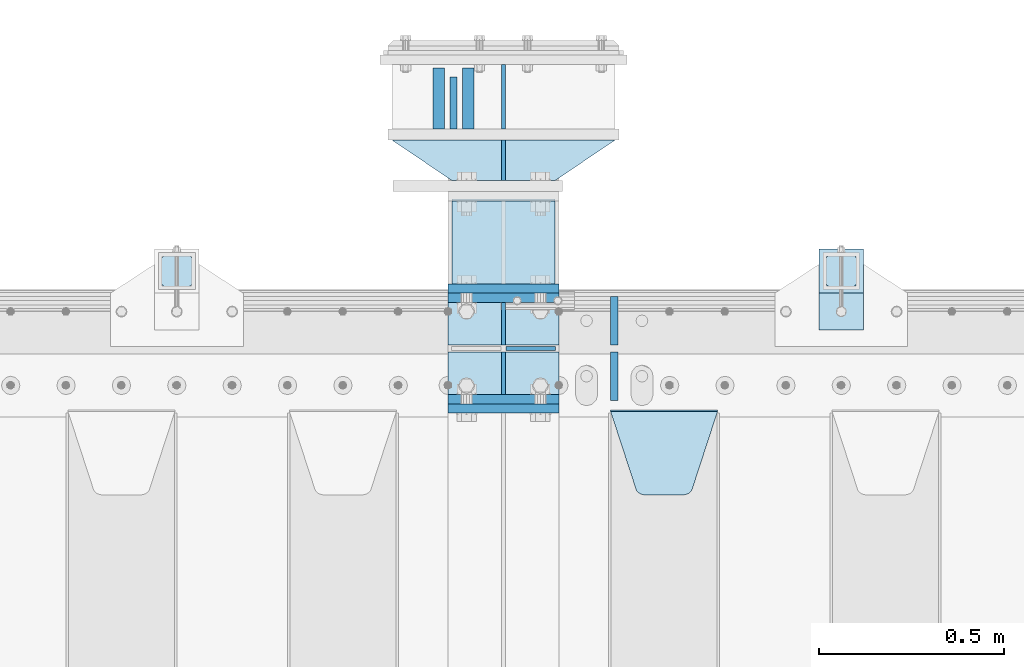
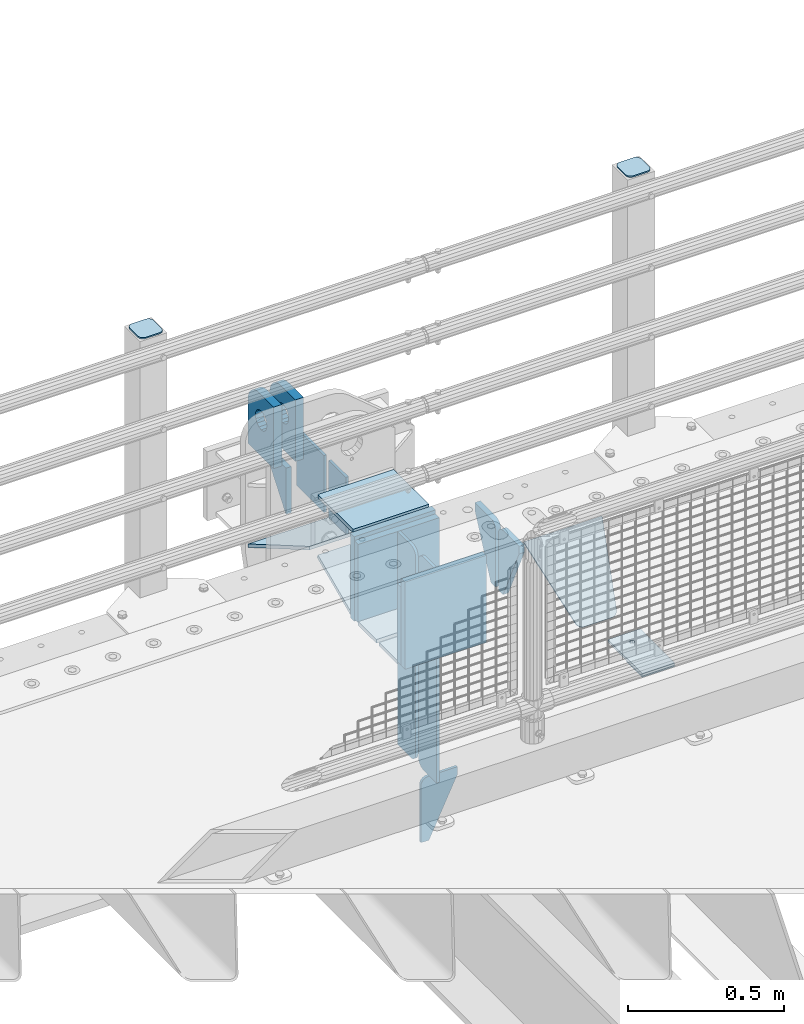
# One storey, part 216 of 242: 26 plates.
"""IFC2X3 building model written with IfcOpenShell, lengths in millimetres."""

from ifc_helpers import new_model, si_unit, frame, origin_with_axes, place, context, subcontext, project, spatial, faceted_brep, material, type_object, element, save


model = new_model("IFC2X3")

# Units and contexts
model_context = context("Model", 3, precision=1e-05, world=origin_with_axes())
body_context = subcontext(model_context, "Body", "Model", "MODEL_VIEW")
ifc_project = project(units=[si_unit("LENGTHUNIT", "METRE", prefix="MILLI"), si_unit("AREAUNIT", "SQUARE_METRE"), si_unit("VOLUMEUNIT", "CUBIC_METRE"), si_unit("MASSUNIT", "GRAM", prefix="KILO"), si_unit("TIMEUNIT", "SECOND"), si_unit("PLANEANGLEUNIT", "RADIAN"), si_unit("SOLIDANGLEUNIT", "STERADIAN"), si_unit("THERMODYNAMICTEMPERATUREUNIT", "DEGREE_CELSIUS"), si_unit("LUMINOUSINTENSITYUNIT", "LUMEN")], contexts=[model_context])

# Site, building, storey
site_placement = place(None, origin_with_axes())
site = spatial("IfcSite", under=ifc_project, at=site_placement, CompositionType="ELEMENT")
building_placement = place(site_placement, origin_with_axes())
building = spatial("IfcBuilding", under=site, at=building_placement, Name="Standard", CompositionType="ELEMENT")
storey_placement = place(building_placement, origin_with_axes())
storey = spatial("IfcBuildingStorey", under=building, at=storey_placement, Name="Undefined", CompositionType="ELEMENT", Elevation=0.0)

# Plates
ifc_material_1 = material(Name="STEEL/S355N")
plate_type_1 = type_object("IfcPlateType", PredefinedType="NOTDEFINED")
plate_1_placement = place(storey_placement, frame((-28555.0000000603, -17824.9999999654, -17.0000182219899), z_axis=(0.0, 1.0, 0.0), x_axis=(1.0, 0.0, 0.0)))
element("IfcPlate", 1, at=plate_1_placement, inside=storey, type_object=plate_type_1, material=ifc_material_1, context=body_context, shape_type="Brep", body=[
    faceted_brep([(0.0, -7.0, 0.0), (0.0, -7.0, 225.0), (0.0, 7.0, 225.0), (0.0, 7.0, 0.0), (280.0, -7.0, 225.0), (280.0, 7.0, 225.0), (280.0, -7.0, 0.0), (280.0, 7.0, 0.0)], [[[0, 1, 2, 3]], [[1, 4, 5, 2]], [[4, 6, 7, 5]], [[6, 0, 3, 7]], [[5, 7, 3, 2]], [[6, 4, 1, 0]]]),
])
plate_type_2 = type_object("IfcPlateType", PredefinedType="NOTDEFINED")
plate_2_placement = place(storey_placement, frame((-28415.0000000603, -17229.9999999654, -24.0000182219899), z_axis=(0.0, 0.0, -1.0), x_axis=(0.0, -1.0, 0.0)))
element("IfcPlate", 2, at=plate_2_placement, inside=storey, type_object=plate_type_2, material=ifc_material_1, context=body_context, shape_type="Brep", body=[
    faceted_brep([(0.0, -5.0, 0.0), (0.0, -5.0, 222.0), (0.0, 5.0, 222.0), (0.0, 5.0, 0.0), (175.0, -5.0, 222.0), (175.0, 5.0, 222.0), (175.0, -5.0, 0.0), (175.0, 5.0, 0.0)], [[[0, 1, 2, 3]], [[1, 4, 5, 2]], [[4, 6, 7, 5]], [[6, 0, 3, 7]], [[5, 7, 3, 2]], [[6, 4, 1, 0]]]),
])
plate_type_3 = type_object("IfcPlateType", PredefinedType="NOTDEFINED")
plate_3_placement = place(storey_placement, frame((-28550.5000000603, -17264.9999999654, -24.0000182219608), z_axis=(0.0, 0.0, -1.0), x_axis=(0.0, -1.0, 0.0)))
element("IfcPlate", 3, at=plate_3_placement, inside=storey, type_object=plate_type_3, material=ifc_material_1, context=body_context, shape_type="Brep", body=[
    faceted_brep([(0.0, -10.0, 0.0), (140.0, -10.0, 180.0), (140.0, 10.0, 180.0), (0.0, 10.0, 0.0), (140.0, -10.0, -1.81898940354586e-12), (140.0, 10.0, -1.81898940354586e-12)], [[[0, 1, 2, 3]], [[1, 4, 5, 2]], [[4, 0, 3, 5]], [[5, 3, 2]], [[4, 1, 0]]]),
])
plate_type_4 = type_object("IfcPlateType", PredefinedType="NOTDEFINED")
plate_4_placement = place(storey_placement, frame((-28510.5000000603, -17404.9999999654, -10.0000182219899), z_axis=(0.0, 1.0, 0.0), x_axis=(0.0, 0.0, 1.0)))
element("IfcPlate", 4, at=plate_4_placement, inside=storey, type_object=plate_type_4, material=ifc_material_1, context=body_context, shape_type="Brep", body=[
    faceted_brep([(113.837049096103, -14.9999989400749, 106.162951053902), (113.837049096103, 15.0000010599251, 106.162950753904), (125.840713002497, 15.0000011401316, 114.183542552921), (125.840713002497, -14.9999988598684, 114.183542852919), (105.816457297088, -14.99999906011, 94.1592871475077), (105.816457297088, 15.00000093989, 94.1592868475091), (103.000000000005, -14.9999992017038, 80.0000001500011), (103.000000000005, 15.0000007982962, 79.9999998500025), (105.816457297088, -14.9999993432975, 65.8407131524946), (105.816457297088, 15.0000006567025, 65.8407128524959), (113.837049096103, -14.9999994633326, 53.8370492460999), (113.837049096103, 15.0000005366674, 53.8370489461013), (125.840713002497, -14.9999995435392, 45.8164574470829), (125.840713002497, 15.0000004564608, 45.8164571470843), (140.000000000005, -14.9999995717044, 43.0000001500011), (140.000000000005, 15.0000004282956, 42.9999998500025), (154.159286997514, -14.9999995435392, 45.8164574470829), (154.159286997514, 15.0000004564608, 45.8164571470843), (166.162950903908, -14.9999994633326, 53.8370492460999), (166.162950903908, 15.0000005366674, 53.8370489461013), (174.183542702923, -14.9999993432975, 65.8407131524946), (174.183542702923, 15.0000006567025, 65.8407128524959), (177.000000000005, -14.9999992017038, 80.0000001500011), (177.000000000005, 15.0000007982962, 79.9999998500025), (174.183542702923, -14.99999906011, 94.1592871475077), (174.183542702923, 15.00000093989, 94.1592868475091), (166.162950903908, -14.9999989400749, 106.162951053902), (166.162950903908, 15.0000010599251, 106.162950753904), (154.159286997514, -14.9999988598684, 114.183542852919), (154.159286997514, 15.0000011401316, 114.183542552921), (140.000000000005, -14.9999988317031, 117.000000150001), (140.000000000005, 15.0000011682969, 116.999999850003), (-1.40620068123098e-06, -15.0, 165.0), (170.0, -15.0, 165.0), (170.0, 15.0, 165.0), (-1.40620068123098e-06, 15.0, 165.000000000004), (188.117333157176, -15.0, 162.614807840237), (188.117333157176, 15.0, 162.614807840237), (205.0, -15.0, 155.621778264911), (205.0, 15.0, 155.621778264911), (219.497474683058, -15.0, 144.497474683059), (219.497474683058, 15.0, 144.497474683059), (230.621778264911, -15.0, 130.0), (230.621778264911, 15.0, 130.0), (237.614807840235, -15.0, 113.117333157177), (237.614807840235, 15.0, 113.117333157177), (240.0, -15.0, 95.0), (240.0, 15.0, 95.0), (240.000015258789, -14.9999999999964, -2.03726813197136e-10), (240.000015258789, 15.0000000000036, -2.03726813197136e-10), (0.0, -15.0, 0.0), (0.0, 15.0, 0.0)], [[[0, 1, 2, 3]], [[4, 5, 1, 0]], [[6, 7, 5, 4]], [[8, 9, 7, 6]], [[10, 11, 9, 8]], [[12, 13, 11, 10]], [[14, 15, 13, 12]], [[16, 17, 15, 14]], [[18, 19, 17, 16]], [[20, 21, 19, 18]], [[22, 23, 21, 20]], [[24, 25, 23, 22]], [[26, 27, 25, 24]], [[28, 29, 27, 26]], [[30, 31, 29, 28]], [[3, 2, 31, 30]], [[32, 33, 34, 35]], [[33, 36, 37, 34]], [[36, 38, 39, 37]], [[38, 40, 41, 39]], [[40, 42, 43, 41]], [[42, 44, 45, 43]], [[44, 46, 47, 45]], [[46, 48, 49, 47]], [[48, 50, 51, 49]], [[34, 37, 39, 41, 43, 45, 47, 49, 51, 35], [19, 21, 23, 25, 27, 29, 31, 2, 1, 5, 7, 9, 11, 13, 15, 17]], [[50, 32, 35, 51]], [[48, 46, 44, 42, 40, 38, 36, 33, 32, 50], [10, 8, 6, 4, 0, 3, 30, 28, 26, 24, 22, 20, 18, 16, 14, 12]]]),
])
plate_5_placement = place(storey_placement, frame((-28590.5000000603, -17404.9999999654, -10.0000182219899), z_axis=(0.0, 1.0, 0.0), x_axis=(0.0, 0.0, 1.0)))
element("IfcPlate", 5, at=plate_5_placement, inside=storey, type_object=plate_type_4, material=ifc_material_1, context=body_context, shape_type="Brep", body=[
    faceted_brep([(113.837049096103, -14.9999989400749, 106.162951053902), (113.837049096103, 15.0000010599251, 106.162950753904), (125.840713002497, 15.0000011401316, 114.183542552921), (125.840713002497, -14.9999988598684, 114.183542852919), (105.816457297088, -14.99999906011, 94.1592871475077), (105.816457297088, 15.00000093989, 94.1592868475091), (103.000000000005, -14.9999992017038, 80.0000001500011), (103.000000000005, 15.0000007982962, 79.9999998500025), (105.816457297088, -14.9999993432975, 65.8407131524946), (105.816457297088, 15.0000006567025, 65.8407128524959), (113.837049096103, -14.9999994633326, 53.8370492460999), (113.837049096103, 15.0000005366674, 53.8370489461013), (125.840713002497, -14.9999995435392, 45.8164574470829), (125.840713002497, 15.0000004564608, 45.8164571470843), (140.000000000005, -14.9999995717044, 43.0000001500011), (140.000000000005, 15.0000004282956, 42.9999998500025), (154.159286997514, -14.9999995435392, 45.8164574470829), (154.159286997514, 15.0000004564608, 45.8164571470843), (166.162950903908, -14.9999994633326, 53.8370492460999), (166.162950903908, 15.0000005366674, 53.8370489461013), (174.183542702923, -14.9999993432975, 65.8407131524946), (174.183542702923, 15.0000006567025, 65.8407128524959), (177.000000000005, -14.9999992017038, 80.0000001500011), (177.000000000005, 15.0000007982962, 79.9999998500025), (174.183542702923, -14.99999906011, 94.1592871475077), (174.183542702923, 15.00000093989, 94.1592868475091), (166.162950903908, -14.9999989400749, 106.162951053902), (166.162950903908, 15.0000010599251, 106.162950753904), (154.159286997514, -14.9999988598684, 114.183542852919), (154.159286997514, 15.0000011401316, 114.183542552921), (140.000000000005, -14.9999988317031, 117.000000150001), (140.000000000005, 15.0000011682969, 116.999999850003), (-1.40620068123098e-06, -15.0, 165.0), (170.0, -15.0, 165.0), (170.0, 15.0, 165.0), (-1.40620068123098e-06, 15.0, 165.000000000004), (188.117333157176, -15.0, 162.614807840237), (188.117333157176, 15.0, 162.614807840237), (205.0, -15.0, 155.621778264911), (205.0, 15.0, 155.621778264911), (219.497474683058, -15.0, 144.497474683059), (219.497474683058, 15.0, 144.497474683059), (230.621778264911, -15.0, 130.0), (230.621778264911, 15.0, 130.0), (237.614807840235, -15.0, 113.117333157177), (237.614807840235, 15.0, 113.117333157177), (240.0, -15.0, 95.0), (240.0, 15.0, 95.0), (240.000015258789, -14.9999999999964, -2.03726813197136e-10), (240.000015258789, 15.0000000000036, -2.03726813197136e-10), (0.0, -15.0, 0.0), (0.0, 15.0, 0.0)], [[[0, 1, 2, 3]], [[4, 5, 1, 0]], [[6, 7, 5, 4]], [[8, 9, 7, 6]], [[10, 11, 9, 8]], [[12, 13, 11, 10]], [[14, 15, 13, 12]], [[16, 17, 15, 14]], [[18, 19, 17, 16]], [[20, 21, 19, 18]], [[22, 23, 21, 20]], [[24, 25, 23, 22]], [[26, 27, 25, 24]], [[28, 29, 27, 26]], [[30, 31, 29, 28]], [[3, 2, 31, 30]], [[32, 33, 34, 35]], [[33, 36, 37, 34]], [[36, 38, 39, 37]], [[38, 40, 41, 39]], [[40, 42, 43, 41]], [[42, 44, 45, 43]], [[44, 46, 47, 45]], [[46, 48, 49, 47]], [[48, 50, 51, 49]], [[34, 37, 39, 41, 43, 45, 47, 49, 51, 35], [19, 21, 23, 25, 27, 29, 31, 2, 1, 5, 7, 9, 11, 13, 15, 17]], [[50, 32, 35, 51]], [[48, 46, 44, 42, 40, 38, 36, 33, 32, 50], [10, 8, 6, 4, 0, 3, 30, 28, 26, 24, 22, 20, 18, 16, 14, 12]]]),
])
ifc_material_2 = material(Name="STEEL/S355J2")
plate_type_5 = type_object("IfcPlateType", PredefinedType="NOTDEFINED")
plate_6_placement = place(storey_placement, frame((-27559.9999999999, -17949.9999999998, -850.000000000002), z_axis=(0.0, 1.0, 0.0), x_axis=(1.0, 0.0, 0.0)))
element("IfcPlate", 6, at=plate_6_placement, inside=storey, type_object=plate_type_5, material=ifc_material_2, context=body_context, shape_type="Brep", body=[
    faceted_brep([(66.3639610305399, -5.0, 163.636038969114), (66.3639610305399, 5.0, 163.636038969114), (59.9999999998618, 5.0, 160.999999999793), (59.9999999998618, -5.0, 160.999999999793), (53.6360389691836, 5.0, 163.636038969114), (53.6360389691836, -5.0, 163.636038969114), (50.9999999998618, 5.0, 169.999999999793), (50.9999999998618, -5.0, 169.999999999793), (53.6360389691836, 5.0, 176.363961030471), (53.6360389691836, -5.0, 176.363961030471), (59.9999999998618, 5.0, 178.999999999793), (59.9999999998618, -5.0, 178.999999999793), (66.3639610305399, 5.0, 176.363961030471), (66.3639610305399, -5.0, 176.363961030471), (68.9999999998618, 5.0, 169.999999999793), (68.9999999998618, -5.0, 169.999999999793), (120.0, -5.0, 0.0), (120.0, -5.0, 220.0), (0.0, -5.0, 220.0), (0.0, -5.0, 0.0), (0.0, 5.0, 0.0), (120.0, 5.0, 0.0), (120.0, 5.0, 220.0), (0.0, 5.0, 220.0)], [[[0, 1, 2, 3]], [[3, 2, 4, 5]], [[5, 4, 6, 7]], [[7, 6, 8, 9]], [[9, 8, 10, 11]], [[11, 10, 12, 13]], [[13, 12, 14, 15]], [[15, 14, 1, 0]], [[16, 17, 18, 19], [11, 13, 15, 0, 3, 5, 7, 9]], [[16, 19, 20, 21]], [[17, 16, 21, 22]], [[18, 17, 22, 23]], [[19, 18, 23, 20]], [[22, 21, 20, 23], [2, 1, 14, 12, 10, 8, 6, 4]]]),
])
plate_type_6 = type_object("IfcPlateType", PredefinedType="NOTDEFINED")
plate_7_placement = place(storey_placement, frame((-27455.9999999999, -17833.9999999998, 1012.50000000001), z_axis=(0.0, 1.0, 0.0), x_axis=(-1.0, 0.0, 0.0)))
element("IfcPlate", 7, at=plate_7_placement, inside=storey, type_object=plate_type_6, material=ifc_material_2, context=body_context, shape_type="Brep", body=[
    faceted_brep([(0.0, -2.5, 19.0), (0.0, -2.5, 69.0), (0.0, 2.5, 69.0), (0.0, 2.5, 19.0), (0.476369668544066, -2.5, 73.2278977451715), (0.476369668544066, 2.5, 73.2278977451715), (1.88159150985302, -2.5, 77.2437910432345), (1.88159150985302, 2.5, 77.2437910432345), (4.14520183310742, -2.5, 80.8463062353148), (4.14520183310742, 2.5, 80.8463062353148), (7.15369376468516, -2.5, 83.8547981668926), (7.15369376468516, 2.5, 83.8547981668926), (10.7562089567655, -2.5, 86.118408490147), (10.7562089567655, 2.5, 86.118408490147), (14.7721022548285, -2.5, 87.5236303314559), (14.7721022548285, 2.5, 87.5236303314559), (19.0, -2.5, 88.0), (19.0, 2.5, 88.0), (69.0, -2.5, 88.0), (69.0, 2.5, 88.0), (73.2278977451715, -2.5, 87.5236303314559), (73.2278977451715, 2.5, 87.5236303314559), (77.2437910432345, -2.5, 86.118408490147), (77.2437910432345, 2.5, 86.118408490147), (80.8463062353148, -2.5, 83.8547981668926), (80.8463062353148, 2.5, 83.8547981668926), (83.8547981668926, -2.5, 80.8463062353148), (83.8547981668926, 2.5, 80.8463062353148), (86.118408490147, -2.5, 77.2437910432345), (86.118408490147, 2.5, 77.2437910432345), (87.5236303314559, -2.5, 73.2278977451715), (87.5236303314559, 2.5, 73.2278977451715), (88.0, -2.5, 69.0), (88.0, 2.5, 69.0), (88.0, -2.5, 19.0), (88.0, 2.5, 19.0), (87.5236303314559, -2.5, 14.7721022548285), (87.5236303314559, 2.5, 14.7721022548285), (86.118408490147, -2.5, 10.7562089567655), (86.118408490147, 2.5, 10.7562089567655), (83.8547981668926, -2.5, 7.15369376468516), (83.8547981668926, 2.5, 7.15369376468516), (80.8463062353148, -2.5, 4.14520183310742), (80.8463062353148, 2.5, 4.14520183310742), (77.2437910432345, -2.5, 1.88159150985302), (77.2437910432345, 2.5, 1.88159150985302), (73.2278977451715, -2.5, 0.476369668544066), (73.2278977451715, 2.5, 0.476369668544066), (69.0, -2.5, 0.0), (69.0, 2.5, 0.0), (19.0, -2.5, 0.0), (19.0, 2.5, 0.0), (14.7721022548285, -2.5, 0.476369668544066), (14.7721022548285, 2.5, 0.476369668544066), (10.7562089567655, -2.5, 1.88159150985302), (10.7562089567655, 2.5, 1.88159150985302), (7.15369376468516, -2.5, 4.14520183310742), (7.15369376468516, 2.5, 4.14520183310742), (4.14520183310742, -2.5, 7.15369376468516), (4.14520183310742, 2.5, 7.15369376468516), (1.88159150985302, -2.5, 10.7562089567655), (1.88159150985302, 2.5, 10.7562089567655), (0.476369668544066, -2.5, 14.7721022548285), (0.476369668544066, 2.5, 14.7721022548285)], [[[0, 1, 2, 3]], [[1, 4, 5, 2]], [[4, 6, 7, 5]], [[6, 8, 9, 7]], [[8, 10, 11, 9]], [[10, 12, 13, 11]], [[12, 14, 15, 13]], [[14, 16, 17, 15]], [[16, 18, 19, 17]], [[18, 20, 21, 19]], [[20, 22, 23, 21]], [[22, 24, 25, 23]], [[24, 26, 27, 25]], [[26, 28, 29, 27]], [[28, 30, 31, 29]], [[30, 32, 33, 31]], [[32, 34, 35, 33]], [[34, 36, 37, 35]], [[36, 38, 39, 37]], [[38, 40, 41, 39]], [[40, 42, 43, 41]], [[42, 44, 45, 43]], [[44, 46, 47, 45]], [[46, 48, 49, 47]], [[48, 50, 51, 49]], [[50, 52, 53, 51]], [[52, 54, 55, 53]], [[54, 56, 57, 55]], [[56, 58, 59, 57]], [[58, 60, 61, 59]], [[60, 62, 63, 61]], [[62, 0, 3, 63]], [[5, 7, 9, 11, 13, 15, 17, 19, 21, 23, 25, 27, 29, 31, 33, 35, 37, 39, 41, 43, 45, 47, 49, 51, 53, 55, 57, 59, 61, 63, 3, 2]], [[62, 60, 58, 56, 54, 52, 50, 48, 46, 44, 42, 40, 38, 36, 34, 32, 30, 28, 26, 24, 22, 20, 18, 16, 14, 12, 10, 8, 6, 4, 1, 0]]]),
])
plate_8_placement = place(storey_placement, frame((-29255.9999999999, -17833.9999999998, 1012.50000000001), z_axis=(0.0, 1.0, 0.0), x_axis=(-1.0, 0.0, 0.0)))
element("IfcPlate", 8, at=plate_8_placement, inside=storey, type_object=plate_type_6, material=ifc_material_2, context=body_context, shape_type="Brep", body=[
    faceted_brep([(0.0, -2.5, 19.0), (0.0, -2.5, 69.0), (0.0, 2.5, 69.0), (0.0, 2.5, 19.0), (0.476369668544066, -2.5, 73.2278977451715), (0.476369668544066, 2.5, 73.2278977451715), (1.88159150985302, -2.5, 77.2437910432345), (1.88159150985302, 2.5, 77.2437910432345), (4.14520183310742, -2.5, 80.8463062353148), (4.14520183310742, 2.5, 80.8463062353148), (7.15369376468516, -2.5, 83.8547981668926), (7.15369376468516, 2.5, 83.8547981668926), (10.7562089567655, -2.5, 86.118408490147), (10.7562089567655, 2.5, 86.118408490147), (14.7721022548285, -2.5, 87.5236303314559), (14.7721022548285, 2.5, 87.5236303314559), (19.0, -2.5, 88.0), (19.0, 2.5, 88.0), (69.0, -2.5, 88.0), (69.0, 2.5, 88.0), (73.2278977451715, -2.5, 87.5236303314559), (73.2278977451715, 2.5, 87.5236303314559), (77.2437910432345, -2.5, 86.118408490147), (77.2437910432345, 2.5, 86.118408490147), (80.8463062353148, -2.5, 83.8547981668926), (80.8463062353148, 2.5, 83.8547981668926), (83.8547981668926, -2.5, 80.8463062353148), (83.8547981668926, 2.5, 80.8463062353148), (86.118408490147, -2.5, 77.2437910432345), (86.118408490147, 2.5, 77.2437910432345), (87.5236303314559, -2.5, 73.2278977451715), (87.5236303314559, 2.5, 73.2278977451715), (88.0, -2.5, 69.0), (88.0, 2.5, 69.0), (88.0, -2.5, 19.0), (88.0, 2.5, 19.0), (87.5236303314559, -2.5, 14.7721022548285), (87.5236303314559, 2.5, 14.7721022548285), (86.118408490147, -2.5, 10.7562089567655), (86.118408490147, 2.5, 10.7562089567655), (83.8547981668926, -2.5, 7.15369376468516), (83.8547981668926, 2.5, 7.15369376468516), (80.8463062353148, -2.5, 4.14520183310742), (80.8463062353148, 2.5, 4.14520183310742), (77.2437910432345, -2.5, 1.88159150985302), (77.2437910432345, 2.5, 1.88159150985302), (73.2278977451715, -2.5, 0.476369668544066), (73.2278977451715, 2.5, 0.476369668544066), (69.0, -2.5, 0.0), (69.0, 2.5, 0.0), (19.0, -2.5, 0.0), (19.0, 2.5, 0.0), (14.7721022548285, -2.5, 0.476369668544066), (14.7721022548285, 2.5, 0.476369668544066), (10.7562089567655, -2.5, 1.88159150985302), (10.7562089567655, 2.5, 1.88159150985302), (7.15369376468516, -2.5, 4.14520183310742), (7.15369376468516, 2.5, 4.14520183310742), (4.14520183310742, -2.5, 7.15369376468516), (4.14520183310742, 2.5, 7.15369376468516), (1.88159150985302, -2.5, 10.7562089567655), (1.88159150985302, 2.5, 10.7562089567655), (0.476369668544066, -2.5, 14.7721022548285), (0.476369668544066, 2.5, 14.7721022548285)], [[[0, 1, 2, 3]], [[1, 4, 5, 2]], [[4, 6, 7, 5]], [[6, 8, 9, 7]], [[8, 10, 11, 9]], [[10, 12, 13, 11]], [[12, 14, 15, 13]], [[14, 16, 17, 15]], [[16, 18, 19, 17]], [[18, 20, 21, 19]], [[20, 22, 23, 21]], [[22, 24, 25, 23]], [[24, 26, 27, 25]], [[26, 28, 29, 27]], [[28, 30, 31, 29]], [[30, 32, 33, 31]], [[32, 34, 35, 33]], [[34, 36, 37, 35]], [[36, 38, 39, 37]], [[38, 40, 41, 39]], [[40, 42, 43, 41]], [[42, 44, 45, 43]], [[44, 46, 47, 45]], [[46, 48, 49, 47]], [[48, 50, 51, 49]], [[50, 52, 53, 51]], [[52, 54, 55, 53]], [[54, 56, 57, 55]], [[56, 58, 59, 57]], [[58, 60, 61, 59]], [[60, 62, 63, 61]], [[62, 0, 3, 63]], [[5, 7, 9, 11, 13, 15, 17, 19, 21, 23, 25, 27, 29, 31, 33, 35, 37, 39, 41, 43, 45, 47, 49, 51, 53, 55, 57, 59, 61, 63, 3, 2]], [[62, 60, 58, 56, 54, 52, 50, 48, 46, 44, 42, 40, 38, 36, 34, 32, 30, 28, 26, 24, 22, 20, 18, 16, 14, 12, 10, 8, 6, 4, 1, 0]]]),
])
plate_type_7 = type_object("IfcPlateType", PredefinedType="NOTDEFINED")
plate_9_placement = place(storey_placement, frame((-27559.9999999999, -17949.9999999998, -857.500000000002), z_axis=(0.0, 1.0, 0.0), x_axis=(1.0, 0.0, 0.0)))
element("IfcPlate", 9, at=plate_9_placement, inside=storey, type_object=plate_type_7, material=ifc_material_2, context=body_context, shape_type="Brep", body=[
    faceted_brep([(0.0, -2.5, 0.0), (0.0, -2.5, 100.0), (0.0, 2.5, 100.0), (0.0, 2.5, 0.0), (120.0, -2.5, 100.0), (120.0, 2.5, 100.0), (120.0, -2.5, 0.0), (120.0, 2.5, 0.0)], [[[0, 1, 2, 3]], [[1, 4, 5, 2]], [[4, 6, 7, 5]], [[6, 0, 3, 7]], [[5, 7, 3, 2]], [[6, 4, 1, 0]]]),
])
plate_type_8 = type_object("IfcPlateType", PredefinedType="NOTDEFINED")
plate_10_placement = place(storey_placement, frame((-28408.4999999426, -18000.0000000349, -925.000018222556), z_axis=(0.0, 0.0, -1.0), x_axis=(1.0, 0.0, 0.0)))
element("IfcPlate", 10, at=plate_10_placement, inside=storey, type_object=plate_type_8, material=ifc_material_1, context=body_context, shape_type="Brep", body=[
    faceted_brep([(0.0, -5.0, 27.0), (0.0, -5.0, 250.0), (0.0, 5.0, 250.0), (0.0, 5.0, 27.0), (30.0, -5.0, 250.0), (30.0, 5.0, 250.0), (135.0, -5.0, 30.0), (135.0, 5.0, 30.0), (135.0, -5.0, 0.0), (135.0, 5.0, 0.0), (27.0, -5.0, 0.0), (27.0, 5.0, 0.0), (22.3114992029914, -5.0, 0.410190668670339), (22.3114992029914, 5.0, 0.410190668670339), (17.7654561302079, -5.0, 1.62829923878041), (17.7654561302079, 5.0, 1.62829923878041), (13.5, -5.0, 3.61731409782021), (13.5, 5.0, 3.61731409782021), (9.64473453846222, -5.0, 6.31680003578765), (9.64473453846222, 5.0, 6.31680003578765), (6.31680003578731, -5.0, 9.64473453846347), (6.31680003578731, 5.0, 9.64473453846347), (3.61731409782078, -5.0, 13.5), (3.61731409782078, 5.0, 13.5), (1.62829923877871, -5.0, 17.765456130207), (1.62829923877871, 5.0, 17.765456130207), (0.410190668670111, -5.0, 22.3114992029929), (0.410190668670111, 5.0, 22.3114992029929)], [[[0, 1, 2, 3]], [[1, 4, 5, 2]], [[4, 6, 7, 5]], [[6, 8, 9, 7]], [[8, 10, 11, 9]], [[10, 12, 13, 11]], [[12, 14, 15, 13]], [[14, 16, 17, 15]], [[16, 18, 19, 17]], [[18, 20, 21, 19]], [[20, 22, 23, 21]], [[22, 24, 25, 23]], [[24, 26, 27, 25]], [[26, 0, 3, 27]], [[5, 7, 9, 11, 13, 15, 17, 19, 21, 23, 25, 27, 3, 2]], [[26, 24, 22, 20, 18, 16, 14, 12, 10, 8, 6, 4, 1, 0]]]),
])
plate_type_9 = type_object("IfcPlateType", PredefinedType="NOTDEFINED")
plate_11_placement = place(storey_placement, frame((-28555.0000000603, -17822.1570307031, -352.396699062332), z_axis=(0.0, 0.913811548702731, 0.406138465867881), x_axis=(1.0, 0.0, 0.0)))
element("IfcPlate", 11, at=plate_11_placement, inside=storey, type_object=plate_type_9, material=ifc_material_1, context=body_context, shape_type="Brep", body=[
    faceted_brep([(0.0, -7.0, 0.0), (0.0, -6.99999999999909, 246.221450805666), (0.0, 6.99999999999909, 246.22145080566), (0.0, 7.0, 0.0), (280.0, -6.99999999999909, 246.221450805666), (280.0, 6.99999999999909, 246.22145080566), (280.0, -7.0, 0.0), (280.0, 7.0, 0.0)], [[[0, 1, 2, 3]], [[1, 4, 5, 2]], [[4, 6, 7, 5]], [[6, 0, 3, 7]], [[5, 7, 3, 2]], [[6, 4, 1, 0]]]),
])
plate_type_10 = type_object("IfcPlateType", PredefinedType="NOTDEFINED")
plate_12_placement = place(storey_placement, frame((-28565.0000000603, -17837.4999999654, -350.00001822199), z_axis=(0.0, 0.0, 1.0), x_axis=(1.0, 0.0, 0.0)))
element("IfcPlate", 12, at=plate_12_placement, inside=storey, type_object=plate_type_10, material=ifc_material_1, context=body_context, shape_type="Brep", body=[
    faceted_brep([(0.0, -12.5, 0.0), (0.0, -12.5, 330.0), (0.0, 12.5, 330.0), (0.0, 12.5, 0.0), (300.0, -12.5, 330.0), (300.0, 12.5, 330.0), (300.0, -12.5, 0.0), (300.0, 12.5, 0.0)], [[[0, 1, 2, 3]], [[1, 4, 5, 2]], [[4, 6, 7, 5]], [[6, 0, 3, 7]], [[5, 7, 3, 2]], [[6, 4, 1, 0]]]),
])
plate_13_placement = place(storey_placement, frame((-28565.0, -18162.5, -340.000000000044), z_axis=(0.0, 0.0, 1.0), x_axis=(1.0, 0.0, 0.0)))
element("IfcPlate", 13, at=plate_13_placement, inside=storey, type_object=plate_type_10, material=ifc_material_1, context=body_context, shape_type="Brep", body=[
    faceted_brep([(0.0, -12.5, 0.0), (9.27684595808387e-10, -12.5, 340.0), (9.27684595808387e-10, 12.5, 340.0), (0.0, 12.5, 0.0), (300.0, -12.5, 340.0), (300.0, 12.5, 340.0), (300.0, -12.5, 0.0), (300.0, 12.5, 0.0)], [[[0, 1, 2, 3]], [[1, 4, 5, 2]], [[4, 6, 7, 5]], [[6, 0, 3, 7]], [[5, 7, 3, 2]], [[6, 4, 1, 0]]]),
])
for number, where, z_axis, x_axis in (
    (14, (-28565.0, -17862.5, -340.0), (0.0, 0.0, 1.0), (1.0, 0.0, 0.0)),
    (15, (-28565.0, -18137.5, -340.0), (0.0, 0.0, 1.0), (1.0, 0.0, 0.0)),
):
    element("IfcPlate", number, at=place(storey_placement, frame(where, z_axis=z_axis, x_axis=x_axis)), inside=storey, type_object=plate_type_10, material=ifc_material_1, context=body_context, shape_type="Brep", body=[
        faceted_brep([(0.0, -12.5, 0.0), (0.0, -12.5, 305.0), (0.0, 12.5, 305.0), (0.0, 12.5, 0.0), (300.0, -12.5, 305.0), (300.0, 12.5, 305.0), (300.0, -12.5, 0.0), (300.0, 12.5, 0.0)], [[[0, 1, 2, 3]], [[1, 4, 5, 2]], [[4, 6, 7, 5]], [[6, 0, 3, 7]], [[5, 7, 3, 2]], [[6, 4, 1, 0]]]),
    ])
plate_type_11 = type_object("IfcPlateType", PredefinedType="NOTDEFINED")
plate_14_placement = place(storey_placement, frame((-28415.0000000603, -17434.9999999654, -24.0000182219899), z_axis=(0.0, 0.0, -1.0), x_axis=(0.0, -1.0, 0.0)))
element("IfcPlate", 16, at=plate_14_placement, inside=storey, type_object=plate_type_11, material=ifc_material_1, context=body_context, shape_type="Brep", body=[
    faceted_brep([(0.0, -5.0, 0.0), (0.0, -5.0, 222.0), (0.0, 5.0, 222.0), (0.0, 5.0, 0.0), (110.0, -5.0, 222.0), (110.0, 5.0, 222.0), (110.0, -5.0, 0.0), (110.0, 5.0, 0.0)], [[[0, 1, 2, 3]], [[1, 4, 5, 2]], [[4, 6, 7, 5]], [[6, 0, 3, 7]], [[5, 7, 3, 2]], [[6, 4, 1, 0]]]),
])
plate_type_12 = type_object("IfcPlateType", PredefinedType="NOTDEFINED")
plate_15_placement = place(storey_placement, frame((-28112.5000000603, -17434.9999999654, -253.00001822199), z_axis=(-0.560566412034006, 0.828109472050236, 0.0), x_axis=(-0.828109472050232, -0.560566412034012, 0.0)))
element("IfcPlate", 17, at=plate_15_placement, inside=storey, type_object=plate_type_12, material=ifc_material_1, context=body_context, shape_type="Brep", body=[
    faceted_brep([(0.0, -7.0, 0.0), (501.006225585945, -7.0, 339.142669677734), (501.006225585945, 7.0, 339.142669677734), (0.0, 7.0, 0.0), (428.100738525391, -7.0, 156.958602905273), (428.100738525391, 7.0, 156.958602905273), (196.230087280281, -7.0, -4.00177668780088e-11), (196.230087280281, 7.0, -4.00177668780088e-11)], [[[0, 1, 2, 3]], [[1, 4, 5, 2]], [[4, 6, 7, 5]], [[6, 0, 3, 7]], [[5, 7, 3, 2]], [[6, 4, 1, 0]]]),
])
plate_type_13 = type_object("IfcPlateType", PredefinedType="NOTDEFINED")
plate_16_placement = place(storey_placement, frame((-28125.0, -18168.2322330441, -1.76776695296576), z_axis=(0.0, -0.707106781186547, -0.707106781186548), x_axis=(1.0, 0.0, 0.0)))
element("IfcPlate", 18, at=plate_16_placement, inside=storey, type_object=plate_type_13, material=ifc_material_1, context=body_context, shape_type="Brep", body=[
    faceted_brep([(0.0, -2.5, 0.0), (69.345504679477, -2.50000000000182, 300.171731424829), (69.345504679477, 2.5, 300.171731424829), (0.0, 2.5, 0.0), (70.9274061199576, -2.5, 304.897442415398), (70.9274061199576, 2.5, 304.897442415398), (73.3818627772307, -2.5, 309.234538108525), (73.3818627772307, 2.50000000000182, 309.234538108529), (76.6187032999551, -2.5, 313.023683126101), (76.6187032999551, 2.50000000000182, 313.023683126103), (80.5190132704993, -2.5, 316.12567259537), (80.5190132704993, 2.5, 316.12567259537), (84.9395038596849, -2.5, 318.426546230474), (84.9395038596849, 2.50000000000182, 318.426546230476), (89.7177759439219, -2.49999999999818, 319.841774983273), (89.7177759439219, 2.50000000000182, 319.841774983273), (94.678286292652, -2.5, 320.319366455076), (94.678286292652, 2.5, 320.319366455076), (195.321713707348, -2.5, 320.319366455076), (195.321713707348, 2.5, 320.319366455076), (200.282224056078, -2.5, 319.841774983272), (200.282224056078, 2.50000000000182, 319.841774983273), (205.060496140315, -2.5, 318.426546230474), (205.060496140315, 2.49999999999818, 318.426546230474), (209.480986729501, -2.49999999999818, 316.12567259537), (209.480986729501, 2.5, 316.12567259537), (213.381296700045, -2.5, 313.023683126101), (213.381296700045, 2.49999999999818, 313.023683126101), (216.618137222769, -2.5, 309.234538108525), (216.618137222769, 2.5, 309.234538108523), (219.072593880042, -2.49999999999818, 304.897442415398), (219.072593880042, 2.50000000000182, 304.897442415398), (220.654495320523, -2.50000000000182, 300.171731424829), (220.654495320523, 2.5, 300.171731424829), (290.0, -2.5, 0.0), (290.0, 2.5, -1.81898940354586e-12)], [[[0, 1, 2, 3]], [[1, 4, 5, 2]], [[4, 6, 7, 5]], [[6, 8, 9, 7]], [[8, 10, 11, 9]], [[10, 12, 13, 11]], [[12, 14, 15, 13]], [[14, 16, 17, 15]], [[16, 18, 19, 17]], [[18, 20, 21, 19]], [[20, 22, 23, 21]], [[22, 24, 25, 23]], [[24, 26, 27, 25]], [[26, 28, 29, 27]], [[28, 30, 31, 29]], [[30, 32, 33, 31]], [[32, 34, 35, 33]], [[34, 0, 3, 35]], [[5, 7, 9, 11, 13, 15, 17, 19, 21, 23, 25, 27, 29, 31, 33, 35, 3, 2]], [[34, 32, 30, 28, 26, 24, 22, 20, 18, 16, 14, 12, 10, 8, 6, 4, 1, 0]]]),
])
plate_type_14 = type_object("IfcPlateType", PredefinedType="NOTDEFINED")
for number, where, z_axis, x_axis in (
    (19, (-28565.0, -18009.25, -343.0), (0.0, -1.0, 0.0), (1.0, 0.0, 0.0)),
    (20, (-28565.0, -17990.75, -343.0), (0.0, 1.0, 0.0), (1.0, 0.0, 0.0)),
):
    element("IfcPlate", number, at=place(storey_placement, frame(where, z_axis=z_axis, x_axis=x_axis)), inside=storey, type_object=plate_type_14, material=ifc_material_1, context=body_context, shape_type="Brep", body=[
        faceted_brep([(0.0, -7.0, 0.0), (0.0, -7.0, 115.75), (0.0, 7.0, 115.75), (0.0, 7.0, 0.0), (300.0, -7.0, 115.75), (300.0, 7.0, 115.75), (300.0, -7.0, 0.0), (300.0, 7.0, 0.0)], [[[0, 1, 2, 3]], [[1, 4, 5, 2]], [[4, 6, 7, 5]], [[6, 0, 3, 7]], [[5, 7, 3, 2]], [[6, 4, 1, 0]]]),
    ])
plate_type_15 = type_object("IfcPlateType", PredefinedType="NOTDEFINED")
for number, where, z_axis, x_axis in (
    (21, (-28415.0, -18009.25, -350.0), (0.0, 0.0, -1.0), (0.0, -1.0, 0.0)),
    (22, (-28415.0, -17990.75, -350.0), (0.0, 0.0, -1.0), (0.0, 1.0, 0.0)),
):
    element("IfcPlate", number, at=place(storey_placement, frame(where, z_axis=z_axis, x_axis=x_axis)), inside=storey, type_object=plate_type_15, material=ifc_material_1, context=body_context, shape_type="Brep", body=[
        faceted_brep([(0.0, -5.0, 0.0), (0.0, -5.0, 485.0), (0.0, 5.0, 485.0), (0.0, 5.0, 0.0), (0.455767409632244, -5.0, 490.209445330008), (0.455767409632244, 5.0, 490.209445330008), (1.80922137642119, -5.0, 495.26060429977), (1.80922137642119, 5.0, 495.26060429977), (4.01923788646673, -5.0, 500.0), (4.01923788646673, 5.0, 500.0), (7.01866670642994, -5.0, 504.283628290596), (7.01866670642994, 5.0, 504.283628290596), (10.7163717094045, -5.0, 507.981333293569), (10.7163717094045, 5.0, 507.981333293569), (15.0, -5.0, 510.980762113533), (15.0, 5.0, 510.980762113533), (19.7393957002314, -5.0, 513.190778623577), (19.7393957002314, 5.0, 513.190778623577), (24.7905546699913, -5.0, 514.544232590366), (24.7905546699913, 5.0, 514.544232590366), (30.0, -5.0, 515.0), (30.0, 5.0, 515.0), (115.75, -5.0, 515.0), (115.75, 5.0, 515.0), (115.75, -5.0, 0.0), (115.75, 5.0, 0.0)], [[[0, 1, 2, 3]], [[1, 4, 5, 2]], [[4, 6, 7, 5]], [[6, 8, 9, 7]], [[8, 10, 11, 9]], [[10, 12, 13, 11]], [[12, 14, 15, 13]], [[14, 16, 17, 15]], [[16, 18, 19, 17]], [[18, 20, 21, 19]], [[20, 22, 23, 21]], [[22, 24, 25, 23]], [[24, 0, 3, 25]], [[5, 7, 9, 11, 13, 15, 17, 19, 21, 23, 25, 3, 2]], [[24, 22, 20, 18, 16, 14, 12, 10, 8, 6, 4, 1, 0]]]),
    ])
for number, where, z_axis, x_axis in (
    (23, (-28415.0, -17990.75, -35.0), (0.0, 0.0, -1.0), (0.0, 1.0, 0.0)),
    (24, (-28415.0, -18009.25, -35.0), (0.0, 0.0, -1.0), (0.0, -1.0, 0.0)),
):
    element("IfcPlate", number, at=place(storey_placement, frame(where, z_axis=z_axis, x_axis=x_axis)), inside=storey, type_object=plate_type_15, material=ifc_material_1, context=body_context, shape_type="Brep", body=[
        faceted_brep([(0.0, -5.0, 30.0), (0.0, -5.0, 301.0), (0.0, 5.0, 301.0), (0.0, 5.0, 30.0), (115.75, -5.0, 301.0), (115.75, 5.0, 301.0), (115.75, -5.0, 0.0), (115.75, 5.0, 0.0), (30.0, -5.0, 0.0), (30.0, 5.0, 0.0), (24.7905546699913, -5.0, 0.455767409633758), (24.7905546699913, 5.0, 0.455767409633758), (19.7393957002314, -5.0, 1.80922137642275), (19.7393957002314, 5.0, 1.80922137642275), (15.0, -5.0, 4.01923788646684), (15.0, 5.0, 4.01923788646684), (10.7163717094045, -5.0, 7.01866670643066), (10.7163717094045, 5.0, 7.01866670643066), (7.01866670642994, -5.0, 10.7163717094038), (7.01866670642994, 5.0, 10.7163717094038), (4.01923788646673, -5.0, 15.0), (4.01923788646673, 5.0, 15.0), (1.80922137642119, -5.0, 19.7393957002299), (1.80922137642119, 5.0, 19.7393957002299), (0.455767409632244, -5.0, 24.7905546699921), (0.455767409632244, 5.0, 24.7905546699921)], [[[0, 1, 2, 3]], [[1, 4, 5, 2]], [[4, 6, 7, 5]], [[6, 8, 9, 7]], [[8, 10, 11, 9]], [[10, 12, 13, 11]], [[12, 14, 15, 13]], [[14, 16, 17, 15]], [[16, 18, 19, 17]], [[18, 20, 21, 19]], [[20, 22, 23, 21]], [[22, 24, 25, 23]], [[24, 0, 3, 25]], [[5, 7, 9, 11, 13, 15, 17, 19, 21, 23, 25, 3, 2]], [[24, 22, 20, 18, 16, 14, 12, 10, 8, 6, 4, 1, 0]]]),
    ])
plate_type_16 = type_object("IfcPlateType", PredefinedType="NOTDEFINED")
for number, where, z_axis, x_axis in (
    (25, (-28115.0, -18141.25, -35.0), (0.0, 0.0, -1.0), (0.0, 1.0, 0.0)),
    (26, (-28115.0, -17858.75, -35.0), (0.0, 0.0, -1.0), (0.0, -1.0, 0.0)),
):
    element("IfcPlate", number, at=place(storey_placement, frame(where, z_axis=z_axis, x_axis=x_axis)), inside=storey, type_object=plate_type_16, material=ifc_material_1, context=body_context, shape_type="Brep", body=[
        faceted_brep([(0.0, -10.0, 0.0), (0.0, -10.0, 30.0), (0.0, 10.0, 30.0), (0.0, 10.0, 0.0), (102.0, -10.0, 250.0), (102.0, 10.0, 250.0), (132.0, -10.0, 250.0), (132.0, 10.0, 250.0), (132.0, -10.0, 30.0), (132.0, 10.0, 30.0), (131.544232590368, -10.0, 24.790554669992), (131.544232590368, 10.0, 24.790554669992), (130.190778623579, -10.0, 19.7393957002299), (130.190778623579, 10.0, 19.7393957002299), (127.980762113533, -10.0, 15.0), (127.980762113533, 10.0, 15.0), (124.98133329357, -10.0, 10.7163717094038), (124.98133329357, 10.0, 10.7163717094038), (121.283628290596, -10.0, 7.01866670643062), (121.283628290596, 10.0, 7.01866670643062), (117.0, -10.0, 4.01923788646684), (117.0, 10.0, 4.01923788646684), (112.260604299769, -10.0, 1.80922137642278), (112.260604299769, 10.0, 1.80922137642278), (107.209445330009, -10.0, 0.455767409633722), (107.209445330009, 10.0, 0.455767409633722), (102.0, -10.0, 0.0), (102.0, 10.0, 0.0)], [[[0, 1, 2, 3]], [[1, 4, 5, 2]], [[4, 6, 7, 5]], [[6, 8, 9, 7]], [[8, 10, 11, 9]], [[10, 12, 13, 11]], [[12, 14, 15, 13]], [[14, 16, 17, 15]], [[16, 18, 19, 17]], [[18, 20, 21, 19]], [[20, 22, 23, 21]], [[22, 24, 25, 23]], [[24, 26, 27, 25]], [[26, 0, 3, 27]], [[5, 7, 9, 11, 13, 15, 17, 19, 21, 23, 25, 27, 3, 2]], [[26, 24, 22, 20, 18, 16, 14, 12, 10, 8, 6, 4, 1, 0]]]),
    ])

save(model, "model.ifc")
